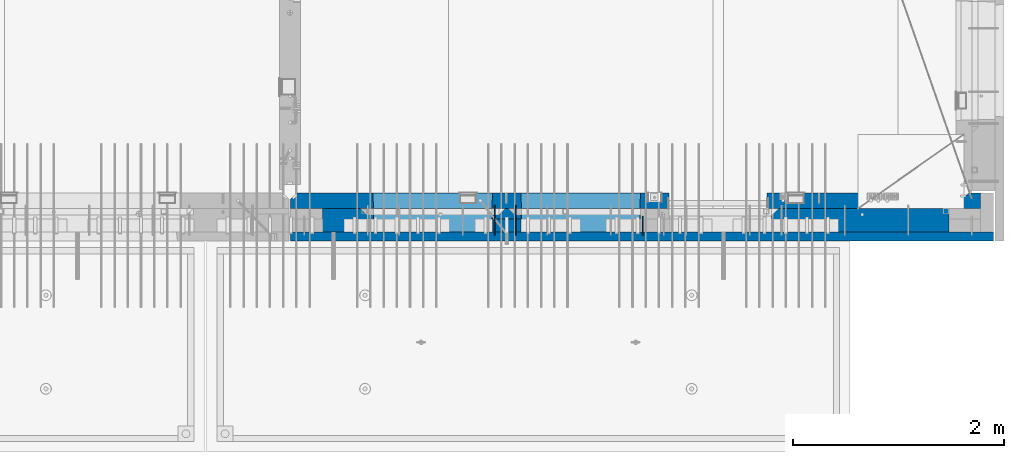
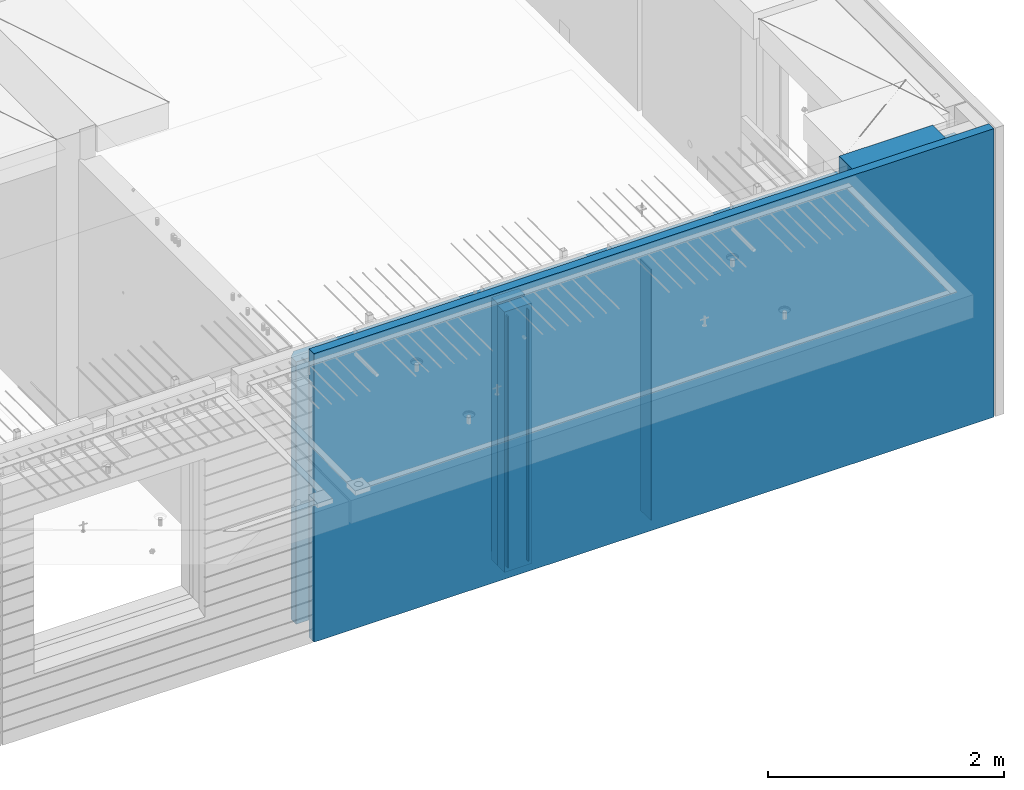
# One storey, part 225 of 341: 8 walls, 1 element without a shape of its own.
"""IFC2X3 building model written with IfcOpenShell, lengths in millimetres."""

from ifc_helpers import new_model, si_unit, frame, origin_with_axes, place, context, subcontext, project, spatial, faceted_brep, material, type_object, element, aggregate, save


model = new_model("IFC2X3")

# Units and contexts
model_context = context("Model", 3, precision=1e-05, world=origin_with_axes())
body_context = subcontext(model_context, "Body", "Model", "MODEL_VIEW")
ifc_project = project(units=[si_unit("LENGTHUNIT", "METRE", prefix="MILLI"), si_unit("AREAUNIT", "SQUARE_METRE"), si_unit("VOLUMEUNIT", "CUBIC_METRE"), si_unit("MASSUNIT", "GRAM", prefix="KILO"), si_unit("TIMEUNIT", "SECOND"), si_unit("PLANEANGLEUNIT", "RADIAN"), si_unit("SOLIDANGLEUNIT", "STERADIAN"), si_unit("THERMODYNAMICTEMPERATUREUNIT", "DEGREE_CELSIUS"), si_unit("LUMINOUSINTENSITYUNIT", "LUMEN")], contexts=[model_context])

# Site, building, storey
site_placement = place(None, origin_with_axes())
site = spatial("IfcSite", under=ifc_project, at=site_placement, CompositionType="ELEMENT")
building_placement = place(site_placement, origin_with_axes())
building = spatial("IfcBuilding", under=site, at=building_placement, CompositionType="ELEMENT")
storey_placement = place(building_placement, origin_with_axes())
storey = spatial("IfcBuildingStorey", under=building, at=storey_placement, Name="5", CompositionType="ELEMENT", Elevation=0.0)

# Assembly, walls
assembly_placement = place(storey_placement, origin_with_axes())
assembly = element("IfcElementAssembly", 1, at=assembly_placement, inside=storey, AssemblyPlace="NOTDEFINED", PredefinedType="REINFORCEMENT_UNIT")
ifc_material_1 = material(Name="Undefined")
wall_type_1 = type_object("IfcWallType", PredefinedType="NOTDEFINED")
wall_1_placement = place(assembly_placement, frame((31944.9998946285, 7780.0, 95115.0), z_axis=(0.0, 0.0, 1.0), x_axis=(0.0, -1.0, 0.0)))
wall_1 = element("IfcWall", 2, at=wall_1_placement, type_object=wall_type_1, material=ifc_material_1, Name="(PD)", context=body_context, shape_type="Brep", body=[
    faceted_brep([(0.0, 5.0, -1300.0), (0.0, 5.0, 1300.0), (180.0, 5.0, 1300.0), (180.0, 5.0, -1300.0), (0.0, -5.0, 1300.0), (180.0, -5.0, 1300.0), (0.0, -5.0, -1300.0), (180.0, -5.0, -1300.0)], [[[0, 1, 2, 3]], [[1, 4, 5, 2]], [[4, 6, 7, 5]], [[6, 0, 3, 7]], [[5, 7, 3, 2]], [[6, 4, 1, 0]]]),
])
wall_2_placement = place(assembly_placement, frame((30545.0021834468, 7880.0, 95115.0), z_axis=(0.0, 0.0, 1.0), x_axis=(0.0, -1.0, 0.0)))
wall_2 = element("IfcWall", 3, at=wall_2_placement, type_object=wall_type_1, material=ifc_material_1, Name="(PD)", context=body_context, shape_type="Brep", body=[
    faceted_brep([(0.0, 5.0, -1300.0), (0.0, 5.0, 1300.0), (280.0, 5.0, 1300.0), (280.0, 5.0, -1300.0), (0.0, -5.0, 1300.0), (280.0, -5.0, 1300.0), (0.0, -5.0, -1300.0), (280.0, -5.0, -1300.0)], [[[0, 1, 2, 3]], [[1, 4, 5, 2]], [[4, 6, 7, 5]], [[6, 0, 3, 7]], [[5, 7, 3, 2]], [[6, 4, 1, 0]]]),
])
wall_3_placement = place(assembly_placement, frame((30745.0021834468, 7880.0, 95115.0), z_axis=(0.0, 0.0, 1.0), x_axis=(0.0, -1.0, 0.0)))
wall_3 = element("IfcWall", 4, at=wall_3_placement, type_object=wall_type_1, material=ifc_material_1, Name="(PD)", context=body_context, shape_type="Brep", body=[
    faceted_brep([(0.0, 5.0, -1300.0), (0.0, 5.0, 1300.0), (280.0, 5.0, 1300.0), (280.0, 5.0, -1300.0), (0.0, -5.0, 1300.0), (280.0, -5.0, 1300.0), (0.0, -5.0, -1300.0), (280.0, -5.0, -1300.0)], [[[0, 1, 2, 3]], [[1, 4, 5, 2]], [[4, 6, 7, 5]], [[6, 0, 3, 7]], [[5, 7, 3, 2]], [[6, 4, 1, 0]]]),
])
ifc_material_2 = material(Name="COS5gt")
wall_type_2 = type_object("IfcWallType", PredefinedType="NOTDEFINED")
wall_4_placement = place(assembly_placement, frame((34845.0, 7740.0, 95247.5), z_axis=(0.0, 0.0, 1.0), x_axis=(-1.0, 3.00000001838171e-08, 0.0)))
wall_4 = element("IfcWall", 5, at=wall_4_placement, type_object=wall_type_2, material=ifc_material_2, context=body_context, shape_type="Brep", body=[
    faceted_brep([(917.0, -110.0, 1492.5), (917.0, -110.0, 1202.5), (917.0, 110.0, 1202.5), (917.0, 110.0, 1492.5), (0.0, 110.0, 1492.5), (0.0, -110.0, 1492.5), (0.0, -110.0, -1492.5), (1680.00110766775, -110.0, -1492.5), (1680.00110766775, -110.0, 857.5), (2649.99996185248, -110.0, 857.5), (2649.99996185248, -110.0, 1202.5), (0.0, 90.0, -1492.5), (1680.00110766775, 90.0, -1492.5), (0.0, 90.0, -1442.5), (1680.00110766775, 90.0, -1442.5), (0.0, 110.0, -1442.5), (1680.00110766775, 110.0, -1442.5), (1680.00110766775, 110.0, 857.5), (2649.99996185248, 110.0, 857.5), (2649.99996185248, -10.0, 857.5), (2649.99996185248, -10.0, 1202.5), (2649.99996185248, 110.0, 1202.5), (4049.99996185248, -10.0, 1202.5), (4049.99996185248, -10.0, -1492.5), (4049.99996185248, 90.0, -1492.5), (4049.99996185248, 90.0, -1442.5), (4049.99996185248, 110.0, -1442.5), (4049.99996185248, 110.0, 1202.5), (2920.0018706072, 110.0, 1202.5), (2920.0018706072, -10.0, 1202.5), (2920.0018706072, -110.0, 1202.5), (4049.99996185248, -110.0, 1202.5), (2920.0018706072, 110.0, -1442.5), (2920.0018706072, 90.0, -1442.5), (2920.0018706072, 90.0, -1492.5), (2920.0018706072, -10.0, -1492.5), (2920.0018706072, -110.0, -1492.5), (4045.94781655315, -110.0, -813.445945945947), (4040.0018706072, 110.0, -807.5), (4010.0018706072, 110.0, -807.5), (2960.0018706072, 110.0, -807.5), (2930.0018706072, 110.0, -807.5), (2924.05592466125, -110.0, -813.445945945947), (4049.99996185248, -110.0, -1492.5), (2924.05592466125, -110.0, 813.445945945947), (4045.94781655315, -110.0, 813.445945945947), (4040.0018706072, 110.0, -802.5), (4040.0018706072, 110.0, 807.5), (2930.0018706072, 110.0, 807.5), (2930.0018706072, 110.0, -802.5), (4320.0018706072, -10.0, 1202.5), (4320.0018706072, 110.0, 1202.5), (4320.0018706072, 110.0, -1442.5), (4320.0018706072, 90.0, -1442.5), (4320.0018706072, 90.0, -1492.5), (4320.0018706072, -10.0, -1492.5), (5928.5, 90.0, -1442.5), (5928.5, 90.0, -1492.5), (5928.5, 110.0, -1442.5), (5928.5, 110.0, -1492.5), (5930.0, -110.0, -1492.5), (5930.0, 110.0, -1492.5), (5930.0, 110.0, 1202.5), (5930.0, -110.0, 1202.5), (4320.0018706072, -110.0, -1492.5), (4320.0018706072, -110.0, 1202.5), (5445.94552773479, -110.0, -813.445945945947), (5439.99958178884, 110.0, -807.5), (5409.99958178884, 110.0, -807.5), (4359.99958178884, 110.0, -807.5), (4329.99958178884, 110.0, -807.5), (4324.05363584289, -110.0, -813.445945945947), (4324.05363584289, -110.0, 813.445945945947), (5445.94552773479, -110.0, 813.445945945947), (5439.99958178884, 110.0, -802.5), (5439.99958178884, 110.0, 807.5), (4329.99958178884, 110.0, 807.5), (4329.99958178884, 110.0, -802.5)], [[[0, 1, 2, 3]], [[4, 5, 0, 3]], [[1, 0, 5, 6, 7, 8, 9, 10]], [[6, 11, 12, 7]], [[11, 13, 14, 12]], [[11, 6, 5, 4, 15, 13]], [[13, 15, 16, 14]], [[7, 12, 14, 16, 17, 8]], [[8, 17, 18, 19, 9]], [[10, 9, 19, 20]], [[2, 1, 10, 20, 21]], [[17, 16, 15, 4, 3, 2, 21, 18]], [[20, 19, 18, 21]], [[22, 23, 24, 25, 26, 27]], [[28, 29, 30, 31, 22, 27]], [[29, 28, 32, 33, 34, 35]], [[30, 29, 35, 36]], [[37, 38, 39, 40, 41, 42]], [[43, 31, 30, 36], [37, 42, 44, 45]], [[46, 38, 37, 45, 47]], [[44, 48, 47, 45]], [[42, 41, 49, 48, 44]], [[32, 28, 27, 26], [41, 40, 39, 38, 46, 47, 48, 49]], [[33, 32, 26, 25]], [[34, 33, 25, 24]], [[34, 24, 23, 43, 36, 35]], [[31, 43, 23, 22]], [[50, 51, 52, 53, 54, 55]], [[56, 57, 54, 53]], [[58, 56, 53, 52]], [[57, 56, 58, 59]], [[60, 61, 62, 63]], [[54, 57, 59, 61, 60, 64, 55]], [[65, 50, 55, 64]], [[66, 67, 68, 69, 70, 71]], [[60, 63, 65, 64], [66, 71, 72, 73]], [[74, 67, 66, 73, 75]], [[72, 76, 75, 73]], [[71, 70, 77, 76, 72]], [[62, 61, 59, 58, 52, 51], [70, 69, 68, 67, 74, 75, 76, 77]], [[65, 63, 62, 51, 50]]]),
])
ifc_material_3 = material(Name="CONCRETE/C30/37")
wall_type_3 = type_object("IfcWallType", PredefinedType="NOTDEFINED")
wall_5_placement = place(assembly_placement, frame((35265.0, 7587.5, 95247.5), z_axis=(0.0, 0.0, 1.0), x_axis=(-1.0, 3.00000001838171e-08, 0.0)))
wall_5 = element("IfcWall", 6, at=wall_5_placement, type_object=wall_type_3, material=ifc_material_3, context=body_context, shape_type="Brep", body=[
    faceted_brep([(0.0, 42.5, -1492.5), (0.0, 42.5, 1492.5), (6650.0, 42.5, 1492.5), (6650.0, 42.5, -1492.5), (0.0, -42.5, 1492.5), (6650.0, -42.5, 1492.5), (0.0, -42.5, -1492.5), (6650.0, -42.5, -1492.5)], [[[0, 1, 2, 3]], [[1, 4, 5, 2]], [[4, 6, 7, 5]], [[6, 0, 3, 7]], [[5, 7, 3, 2]], [[6, 4, 1, 0]]]),
])
ifc_material_4 = material(Name="CONCRETE/C35/45")
wall_type_4 = type_object("IfcWallType", PredefinedType="NOTDEFINED")
wall_6_placement = place(assembly_placement, frame((35145.0, 7925.0, 95112.5), z_axis=(0.0, 0.0, 1.0), x_axis=(-1.0, 3.00000001838171e-08, 0.0)))
wall_6 = element("IfcWall", 7, at=wall_6_placement, type_object=wall_type_4, material=ifc_material_4, context=body_context, shape_type="Brep", body=[
    faceted_brep([(202.000000451517, -54.9999973486238, 1357.5), (202.000000451517, -54.9999973486238, -1357.5), (214.999999722531, -75.0, -1357.5), (214.999999722531, -75.0, 1357.5), (128.000000410604, -54.9999993903875, 1357.5), (128.000000410604, -54.9999993903875, -1357.5), (115.0, -75.0, 1357.5), (115.0, -75.0, -1357.5), (0.0, -75.0, -1357.5), (0.0, -75.0, 1357.5), (0.0, 75.0, 1357.5), (0.0, 75.0, -1357.5), (6470.0, -75.0, 1357.5), (6530.0, -15.0, 1357.5), (6530.0, 75.0, 1357.5), (6530.0, 75.0, -1357.5), (6530.0, -15.0, -1357.5), (6470.0, -75.0, -1357.5), (2950.00110766775, -75.0, -1357.5), (2946.15495382159, 75.0, -1357.5), (2950.00110766775, -75.0, 952.5), (2946.1549538216, 75.0, 948.653846153844), (2020.00110766775, -75.0, 952.5), (2023.8472615139, 75.0, 948.653846153844), (2020.00110766775, -75.0, -1357.5), (2023.8472615139, 75.0, -1357.5), (5749.99958178884, -75.0, -682.5), (5745.94552773479, 75.0, -678.445945945947), (4624.05363584289, 75.0, -678.445945945947), (4619.99958178884, -75.0, -682.5), (5749.99958178884, -75.0, 952.5), (5745.94552773479, 75.0, 948.445945945947), (4619.99958178884, -75.0, 952.5), (4624.05363584289, 75.0, 948.445945945947), (4345.94781655315, 75.0, -678.445945945947), (4345.94781655315, 75.0, 948.445945945947), (3224.05592466125, 75.0, 948.445945945947), (3224.05592466125, 75.0, -678.445945945947), (3220.0018706072, -75.0, -682.5), (3220.0018706072, -75.0, 952.5), (4350.0018706072, -75.0, -682.5), (4350.0018706072, -75.0, 952.5)], [[[0, 1, 2, 3]], [[4, 5, 1, 0]], [[6, 7, 5, 4]], [[8, 9, 10, 11]], [[0, 3, 12, 13, 14, 10, 9, 6, 4]], [[15, 14, 13, 16]], [[12, 17, 16, 13]], [[15, 16, 17, 18, 19]], [[19, 18, 20, 21]], [[22, 23, 21, 20]], [[24, 25, 23, 22]], [[26, 27, 28, 29]], [[27, 26, 30, 31]], [[32, 33, 31, 30]], [[29, 28, 33, 32]], [[11, 10, 14, 15, 19, 21, 23, 25], [34, 35, 36, 37], [27, 31, 33, 28]], [[38, 37, 36, 39]], [[40, 34, 37, 38]], [[34, 40, 41, 35]], [[39, 36, 35, 41]], [[24, 22, 20, 18, 17, 12, 3, 2], [40, 38, 39, 41], [26, 29, 32, 30]], [[8, 11, 25, 24, 2, 1, 5, 7]], [[9, 8, 7, 6]]]),
])
wall_type_5 = type_object("IfcWallType", PredefinedType="NOTDEFINED")
wall_7_placement = place(assembly_placement, frame((30795.0000381475, 7800.0, 95112.5), z_axis=(0.0, 0.0, 1.0), x_axis=(-1.0, 3.00000001838171e-08, 0.0)))
wall_7 = element("IfcWall", 8, at=wall_7_placement, type_object=wall_type_5, material=ifc_material_4, context=body_context, shape_type="Brep", body=[
    faceted_brep([(0.0, 50.0, -1357.5), (0.0, 50.0, 1357.5), (270.001908754726, 50.0, 1357.5), (270.001908754726, 50.0, -1357.5), (0.0, -50.0, 1357.5), (270.001908754726, -50.0, 1357.5), (0.0, -50.0, -1357.5), (270.001908754726, -50.0, -1357.5)], [[[0, 1, 2, 3]], [[1, 4, 5, 2]], [[4, 6, 7, 5]], [[6, 0, 3, 7]], [[5, 7, 3, 2]], [[6, 4, 1, 0]]]),
])
ifc_material_5 = material(Name="SPU")
wall_type_6 = type_object("IfcWallType", PredefinedType="NOTDEFINED")
wall_8_placement = place(assembly_placement, frame((30795.0000381475, 7690.0, 95102.5), z_axis=(0.0, 0.0, 1.0), x_axis=(-1.0, 3.00000001838171e-08, 0.0)))
wall_8 = element("IfcWall", 9, at=wall_8_placement, type_object=wall_type_6, material=ifc_material_5, context=body_context, shape_type="Brep", body=[
    faceted_brep([(0.0, 60.0, -1347.5), (0.0, 60.0, 1347.5), (270.001908754726, 60.0, 1347.5), (270.001908754726, 60.0, -1347.5), (0.0, -60.0, 1347.5), (270.001908754726, -60.0, 1347.5), (0.0, -60.0, -1347.5), (270.001908754726, -60.0, -1347.5)], [[[0, 1, 2, 3]], [[1, 4, 5, 2]], [[4, 6, 7, 5]], [[6, 0, 3, 7]], [[5, 7, 3, 2]], [[6, 4, 1, 0]]]),
])
aggregate(assembly, [wall_8, wall_7, wall_1, wall_2, wall_3, wall_4, wall_5, wall_6])

save(model, "model.ifc")
